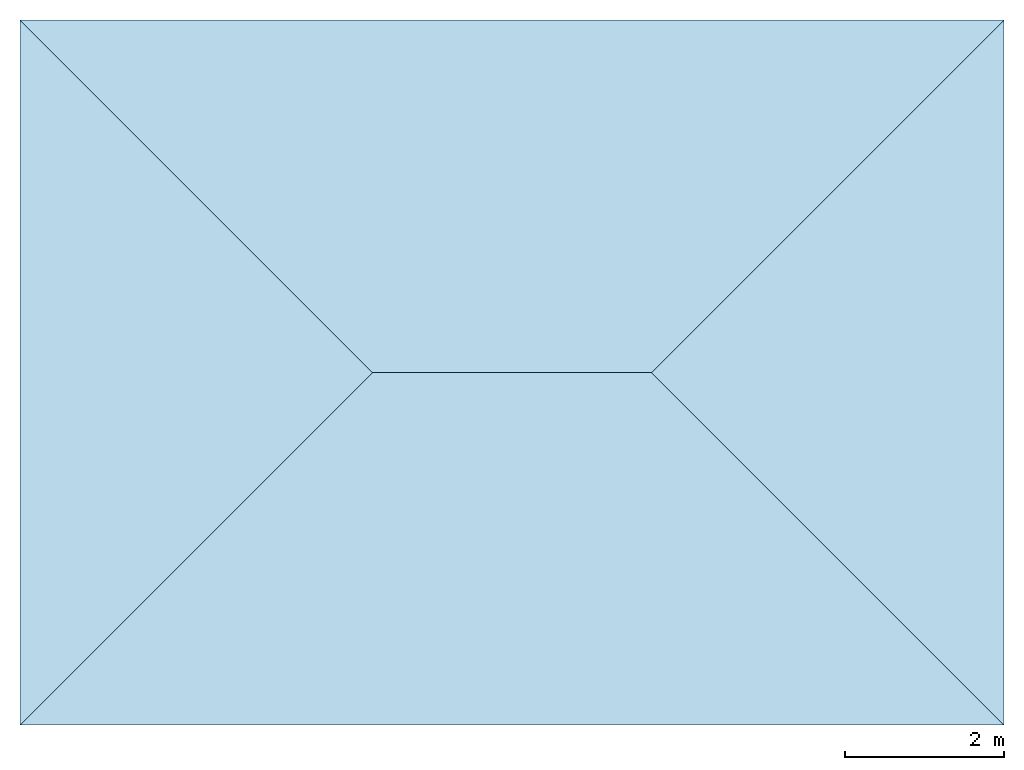
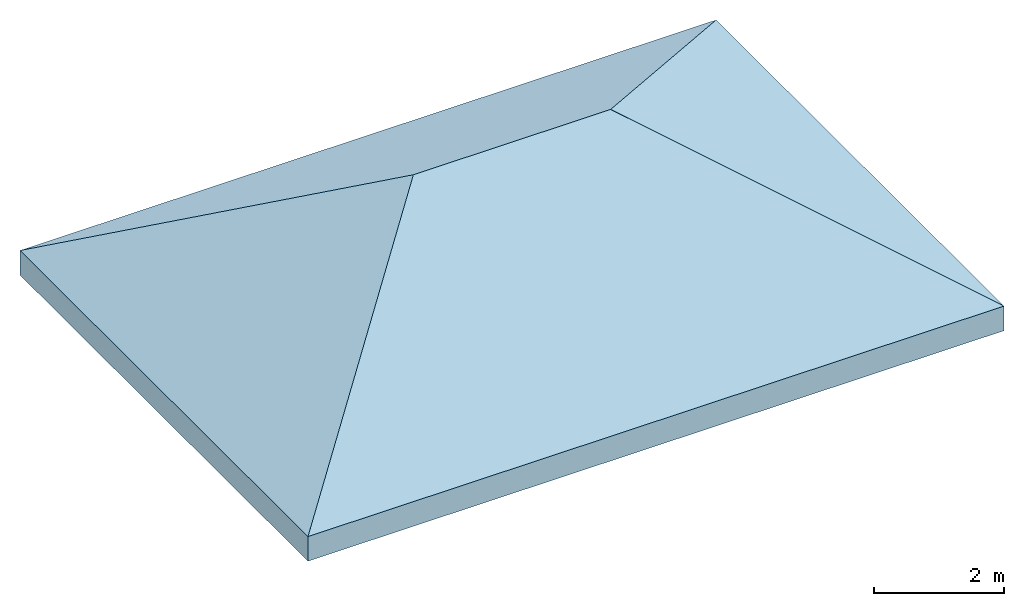
# One storey: 4 slabs, 1 element without a shape of its own.
"""IFC4 building model written with IfcOpenShell, lengths in millimetres."""

from ifc_helpers import new_model, entity, si_unit, converted_unit, derived_unit, direction, frame, origin, place, context, subcontext, project, spatial, polyline, outline, extrude, type_object, element, aggregate, save


model = new_model("IFC4")

# Units and contexts
model_context = context("Model", 3, precision=0.01, world=origin(), true_north=direction((6.12303176911189e-17, 1.0)))
body_context = subcontext(model_context, "Body", "Model", "MODEL_VIEW")
ifc_project = project(units=[si_unit("LENGTHUNIT", "METRE", prefix="MILLI"), si_unit("AREAUNIT", "SQUARE_METRE"), si_unit("VOLUMEUNIT", "CUBIC_METRE"), converted_unit("PLANEANGLEUNIT", "DEGREE", entity("IfcRatioMeasure", 0.0174532925199433), si_unit("PLANEANGLEUNIT", "RADIAN"), dimensions=[0, 0, 0, 0, 0, 0, 0]), si_unit("MASSUNIT", "GRAM", prefix="KILO"), derived_unit("MASSDENSITYUNIT", [(si_unit("MASSUNIT", "GRAM", prefix="KILO"), 1), (si_unit("LENGTHUNIT", "METRE"), -3)]), derived_unit("MOMENTOFINERTIAUNIT", [(si_unit("LENGTHUNIT", "METRE"), 4)]), si_unit("TIMEUNIT", "SECOND"), si_unit("FREQUENCYUNIT", "HERTZ"), si_unit("THERMODYNAMICTEMPERATUREUNIT", "DEGREE_CELSIUS"), derived_unit("THERMALTRANSMITTANCEUNIT", [(si_unit("MASSUNIT", "GRAM", prefix="KILO"), 1), (si_unit("THERMODYNAMICTEMPERATUREUNIT", "KELVIN"), -1), (si_unit("TIMEUNIT", "SECOND"), -3)]), derived_unit("VOLUMETRICFLOWRATEUNIT", [(si_unit("LENGTHUNIT", "METRE"), 3), (si_unit("TIMEUNIT", "SECOND"), -1)]), si_unit("ELECTRICCURRENTUNIT", "AMPERE"), si_unit("ELECTRICVOLTAGEUNIT", "VOLT"), si_unit("POWERUNIT", "WATT"), si_unit("FORCEUNIT", "NEWTON", prefix="KILO"), si_unit("ILLUMINANCEUNIT", "LUX"), si_unit("LUMINOUSFLUXUNIT", "LUMEN"), si_unit("LUMINOUSINTENSITYUNIT", "CANDELA"), derived_unit("USERDEFINED", [(si_unit("MASSUNIT", "GRAM", prefix="KILO"), -1), (si_unit("LENGTHUNIT", "METRE"), -2), (si_unit("TIMEUNIT", "SECOND"), 3), (si_unit("LUMINOUSFLUXUNIT", "LUMEN"), 1)]), derived_unit("LINEARVELOCITYUNIT", [(si_unit("LENGTHUNIT", "METRE"), 1), (si_unit("TIMEUNIT", "SECOND"), -1)]), si_unit("PRESSUREUNIT", "PASCAL"), derived_unit("USERDEFINED", [(si_unit("LENGTHUNIT", "METRE"), -2), (si_unit("MASSUNIT", "GRAM", prefix="KILO"), 1), (si_unit("TIMEUNIT", "SECOND"), -2)]), derived_unit("LINEARFORCEUNIT", [(si_unit("MASSUNIT", "GRAM", prefix="KILO"), 1), (si_unit("LENGTHUNIT", "METRE"), 1), (si_unit("TIMEUNIT", "SECOND"), -2), (si_unit("LENGTHUNIT", "METRE"), -1)]), derived_unit("PLANARFORCEUNIT", [(si_unit("MASSUNIT", "GRAM", prefix="KILO"), 1), (si_unit("LENGTHUNIT", "METRE"), 1), (si_unit("TIMEUNIT", "SECOND"), -2), (si_unit("LENGTHUNIT", "METRE"), -2)])], contexts=[model_context])

# Site, building, storey
site_placement = place(None, origin())
site = spatial("IfcSite", under=ifc_project, at=site_placement, CompositionType="ELEMENT")
building_placement = place(site_placement, origin())
building = spatial("IfcBuilding", under=site, at=building_placement, CompositionType="ELEMENT")
storey_placement = place(building_placement, frame((0.0, 0.0, 3500.0)))
storey = spatial("IfcBuildingStorey", under=building, at=storey_placement, Name="Level 2", CompositionType="ELEMENT", Elevation=3500.0)

# Roof, slabs
roof_placement = place(storey_placement, frame((-16184.8266444612, -4109.47133073575, 0.0)))
roof = element("IfcRoof", 1, at=roof_placement, inside=storey, Name="Basic Roof:Generic - 400mm", ObjectType="Basic Roof:Generic - 400mm", PredefinedType="NOTDEFINED")
slab_type_1 = type_object("IfcSlabType", Name="Basic Roof:Generic - 400mm", PredefinedType="ROOF")
slab_1_placement = place(roof_placement, origin())
slab_1 = element("IfcSlab", 2, at=slab_1_placement, type_object=slab_type_1, Name="Basic Roof:Generic - 400mm", ObjectType="Basic Roof:Generic - 400mm", PredefinedType="NOTDEFINED", context=body_context, shape_type="SweptSolid", body=[
    extrude(outline(polyline([(2554.77494116409, 0.0), (-2554.77494116409, 4425.0), (-2554.7749411641, -4425.0), (2554.77494116409, 0.0)])), frame((2212.50000000001, 4425.0, 1277.38747058204), z_axis=(-0.499999999999999, 0.0, 0.866025403784439), x_axis=(0.866025403784439, 0.0, 0.499999999999999)), (0.499999999999999, 0.0, 0.866025403784439), 461.880215351703),
])
slab_type_2 = type_object("IfcSlabType", Name="Basic Roof:Generic - 400mm", PredefinedType="ROOF")
slab_2_placement = place(roof_placement, origin())
slab_2 = element("IfcSlab", 3, at=slab_2_placement, type_object=slab_type_2, Name="Basic Roof:Generic - 400mm", ObjectType="Basic Roof:Generic - 400mm", PredefinedType="NOTDEFINED", context=body_context, shape_type="SweptSolid", body=[
    extrude(outline(polyline([(-6175.0, -2554.77494116408), (6175.0, -2554.77494116411), (1750.0, 2554.77494116409), (-1750.0, 2554.7749411641), (-6175.0, -2554.77494116408)])), frame((6175.0, 2212.50000000002, 1277.38747058204), z_axis=(0.0, -0.499999999999999, 0.866025403784439), x_axis=(1.0, 0.0, 0.0)), (0.0, 0.499999999999999, 0.866025403784439), 461.880215351703),
])
slab_type_3 = type_object("IfcSlabType", Name="Basic Roof:Generic - 400mm", PredefinedType="ROOF")
slab_3_placement = place(roof_placement, origin())
slab_3 = element("IfcSlab", 4, at=slab_3_placement, type_object=slab_type_3, Name="Basic Roof:Generic - 400mm", ObjectType="Basic Roof:Generic - 400mm", PredefinedType="NOTDEFINED", context=body_context, shape_type="SweptSolid", body=[
    extrude(outline(polyline([(2554.77494116408, -4425.0), (2554.7749411641, 4425.0), (-2554.77494116409, 0.0), (2554.77494116408, -4425.0)])), frame((10137.5, 4425.0, 1277.38747058204), z_axis=(0.499999999999999, 0.0, 0.866025403784439), x_axis=(0.866025403784439, 0.0, -0.499999999999999)), (-0.499999999999999, 0.0, 0.866025403784439), 461.880215351703),
])
slab_type_4 = type_object("IfcSlabType", Name="Basic Roof:Generic - 400mm", PredefinedType="ROOF")
slab_4_placement = place(roof_placement, origin())
slab_4 = element("IfcSlab", 5, at=slab_4_placement, type_object=slab_type_4, Name="Basic Roof:Generic - 400mm", ObjectType="Basic Roof:Generic - 400mm", PredefinedType="NOTDEFINED", context=body_context, shape_type="SweptSolid", body=[
    extrude(outline(polyline([(6175.0, 2554.77494116408), (-6175.0, 2554.77494116411), (-1750.0, -2554.77494116409), (1750.0, -2554.7749411641), (6175.0, 2554.77494116408)])), frame((6175.0, 6637.50000000002, 1277.38747058205), z_axis=(0.0, 0.499999999999999, 0.866025403784439), x_axis=(1.0, 0.0, 0.0)), (0.0, -0.499999999999999, 0.866025403784439), 461.880215351703),
])
aggregate(roof, [slab_1, slab_2, slab_3, slab_4])

save(model, "model.ifc")
